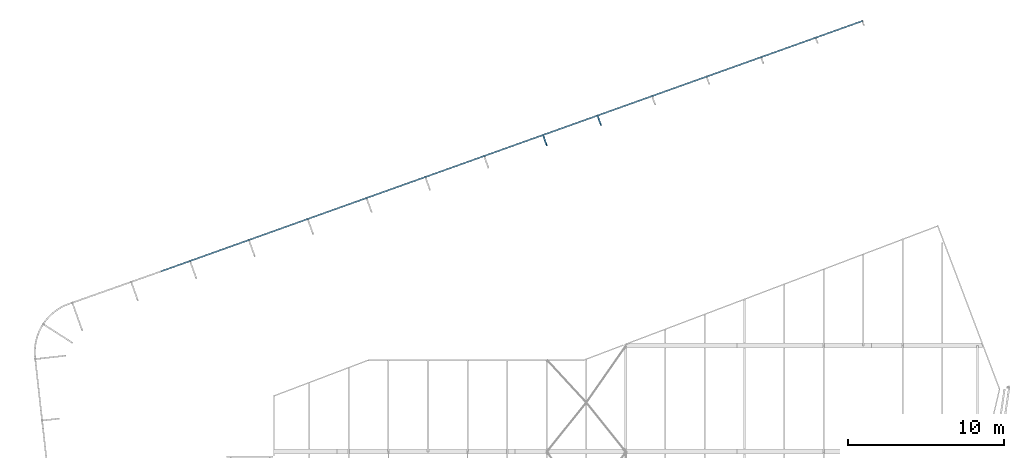
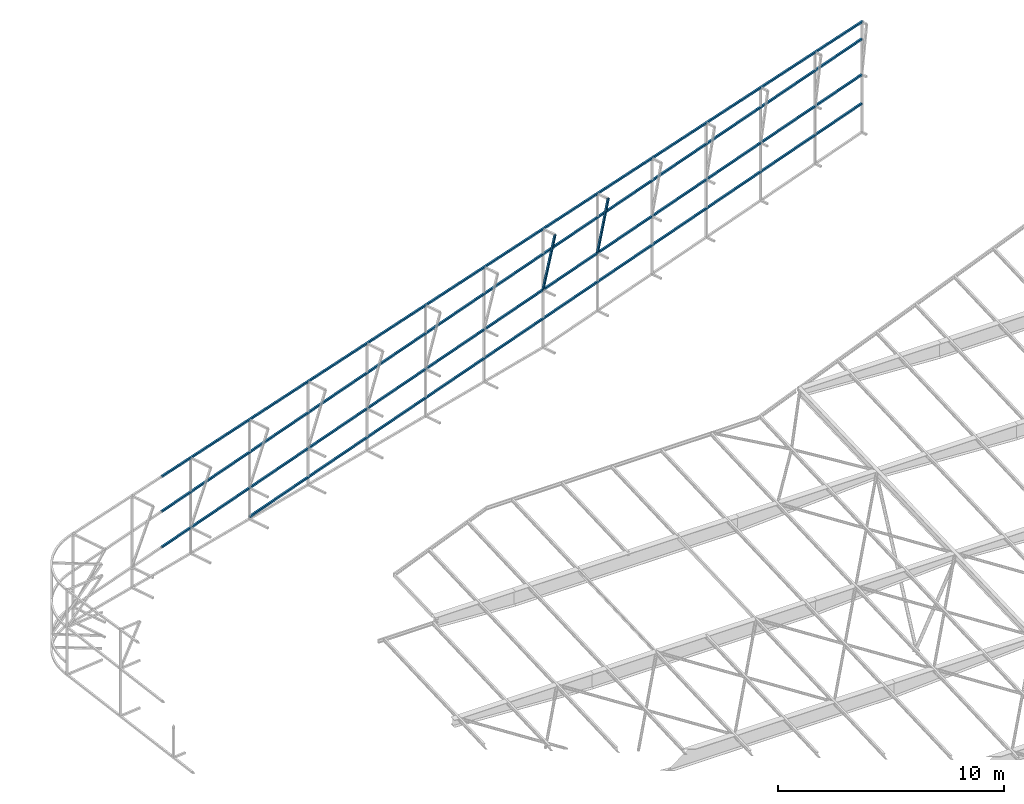
# One storey, part 133 of 215: 4 beams, 2 members, 6 elements without a shape of their own.
"""IFC2X3 building model written with IfcOpenShell, lengths in millimetres."""

from ifc_helpers import new_model, si_unit, frame, origin_with_axes, origin_2d_with_axis, place, context, subcontext, project, spatial, hollow_rectangle, extrude, material, type_object, element, aggregate, save


model = new_model("IFC2X3")

# Units and contexts
model_context = context("Model", 3, precision=1e-05, world=origin_with_axes())
body_context = subcontext(model_context, "Body", "Model", "MODEL_VIEW")
ifc_project = project(units=[si_unit("LENGTHUNIT", "METRE", prefix="MILLI"), si_unit("AREAUNIT", "SQUARE_METRE"), si_unit("VOLUMEUNIT", "CUBIC_METRE"), si_unit("MASSUNIT", "GRAM", prefix="KILO"), si_unit("TIMEUNIT", "SECOND"), si_unit("PLANEANGLEUNIT", "RADIAN"), si_unit("SOLIDANGLEUNIT", "STERADIAN"), si_unit("THERMODYNAMICTEMPERATUREUNIT", "DEGREE_CELSIUS"), si_unit("LUMINOUSINTENSITYUNIT", "LUMEN")], contexts=[model_context])

# Site, building, storey
site_placement = place(None, origin_with_axes())
site = spatial("IfcSite", under=ifc_project, at=site_placement, CompositionType="ELEMENT")
building_placement = place(site_placement, origin_with_axes())
building = spatial("IfcBuilding", under=site, at=building_placement, Name="Undefined", CompositionType="ELEMENT")
storey_placement = place(building_placement, origin_with_axes())
storey = spatial("IfcBuildingStorey", under=building, at=storey_placement, Name="Undefined", CompositionType="ELEMENT", Elevation=0.0)

# Assembly, beam
assembly_1_placement = place(storey_placement, origin_with_axes())
assembly_1 = element("IfcElementAssembly", 1, at=assembly_1_placement, inside=storey, Name="Steel Assembly", AssemblyPlace="NOTDEFINED", PredefinedType="RIGID_FRAME")
ifc_material = material(Name="STEEL/S275JR")
beam_type = type_object("IfcBeamType", PredefinedType="NOTDEFINED")
beam_1_placement = place(assembly_1_placement, frame((105326.104020235, 76175.269389609, 1704.99989208878), z_axis=(0.0, 0.0, -1.0), x_axis=(0.941802170974673, 0.33616762299096, 0.0)))
beam_1 = element("IfcBeam", 2, at=beam_1_placement, type_object=beam_type, material=ifc_material, Name="LISSE", context=body_context, shape_type="SweptSolid", body=[
    extrude(hollow_rectangle(XDim=100.0, YDim=100.0, WallThickness=4.0, InnerFilletRadius=4.0, OuterFilletRadius=8.0, at=origin_2d_with_axis()), frame((41820.4772396688, 7.27595761418343e-12, 0.0), z_axis=(-1.0, 0.0, 0.0), x_axis=(-6.93889390390723e-18, -1.0, -3.46944695195361e-18)), (0.0, 0.0, 1.0), 41820.5),
])
aggregate(assembly_1, [beam_1])

assembly_2_placement = place(storey_placement, origin_with_axes())
assembly_2 = element("IfcElementAssembly", 3, at=assembly_2_placement, inside=storey, Name="Steel Assembly", AssemblyPlace="NOTDEFINED", PredefinedType="RIGID_FRAME")
beam_2_placement = place(assembly_2_placement, frame((99675.6177684888, 74158.3802872295, 5186.05790994558), z_axis=(0.0, 0.0, -1.0), x_axis=(0.941802170974673, 0.33616762299096, 0.0)))
beam_2 = element("IfcBeam", 4, at=beam_2_placement, type_object=beam_type, material=ifc_material, Name="LISSE", context=body_context, shape_type="SweptSolid", body=[
    extrude(hollow_rectangle(XDim=100.0, YDim=100.0, WallThickness=4.0, InnerFilletRadius=4.0, OuterFilletRadius=8.0, at=origin_2d_with_axis()), frame((47820.128325497, -2.65455037537482e-12, 0.0), z_axis=(-1.0, 0.0, 0.0), x_axis=(-6.93889390390723e-18, -1.0, -3.46944695195361e-18)), (0.0, 0.0, 1.0), 47820.1),
])
aggregate(assembly_2, [beam_2])

assembly_3_placement = place(storey_placement, origin_with_axes())
assembly_3 = element("IfcElementAssembly", 5, at=assembly_3_placement, inside=storey, Name="Steel Assembly", AssemblyPlace="NOTDEFINED", PredefinedType="RIGID_FRAME")
beam_3_placement = place(assembly_3_placement, frame((99675.6177684151, 74158.380287177, 3259.99790994558), z_axis=(0.0, 0.0, -1.0), x_axis=(0.941802170974673, 0.33616762299096, 0.0)))
beam_3 = element("IfcBeam", 6, at=beam_3_placement, type_object=beam_type, material=ifc_material, Name="LISSE", context=body_context, shape_type="SweptSolid", body=[
    extrude(hollow_rectangle(XDim=100.0, YDim=100.0, WallThickness=4.0, InnerFilletRadius=4.0, OuterFilletRadius=8.0, at=origin_2d_with_axis()), frame((47820.128325497, -2.65455037537482e-12, 0.0), z_axis=(-1.0, 0.0, 0.0), x_axis=(-6.93889390390723e-18, -1.0, -3.46944695195361e-18)), (0.0, 0.0, 1.0), 47820.1),
])
aggregate(assembly_3, [beam_3])

assembly_4_placement = place(storey_placement, origin_with_axes())
assembly_4 = element("IfcElementAssembly", 7, at=assembly_4_placement, inside=storey, Name="Steel Assembly", AssemblyPlace="NOTDEFINED", PredefinedType="RIGID_FRAME")
beam_4_placement = place(assembly_4_placement, frame((99674.668114869, 74158.0409739412, 7070.43562400573), z_axis=(-0.0189932160034524, -0.0067863100012285, -0.999796581181599), x_axis=(0.941610590477688, 0.336099240813566, -0.0201691899888121)))
beam_4 = element("IfcBeam", 8, at=beam_4_placement, type_object=beam_type, material=ifc_material, Name="LISSE", context=body_context, shape_type="SweptSolid", body=[
    extrude(hollow_rectangle(XDim=100.0, YDim=100.0, WallThickness=4.0, InnerFilletRadius=4.0, OuterFilletRadius=8.0, at=origin_2d_with_axis()), frame((47882.3866464287, 1.51911999189181e-11, -1.66125400402717e-13), z_axis=(-1.0, 0.0, 0.0), x_axis=(-6.93889390390723e-18, -1.0, -3.46944695195361e-18)), (0.0, 0.0, 1.0), 47882.4),
])
aggregate(assembly_4, [beam_4])

# Assembly, member
assembly_5_placement = place(storey_placement, origin_with_axes())
assembly_5 = element("IfcElementAssembly", 9, at=assembly_5_placement, inside=storey, Name="Steel Assembly", AssemblyPlace="NOTDEFINED", PredefinedType="RIGID_FRAME")
member_type = type_object("IfcMemberType", PredefinedType="NOTDEFINED")
member_1_placement = place(assembly_5_placement, frame((127920.570362248, 83569.4991896166, 6504.04384983193), z_axis=(0.941802170974673, 0.33616762299096, 0.0), x_axis=(-0.0642444429927004, 0.17998634797955, -0.981568930888474)))
member_1 = element("IfcMember", 10, at=member_1_placement, type_object=member_type, material=ifc_material, Name="LISSE", context=body_context, shape_type="SweptSolid", body=[
    extrude(hollow_rectangle(XDim=100.0, YDim=100.0, WallThickness=4.0, InnerFilletRadius=4.0, OuterFilletRadius=8.0, at=origin_2d_with_axis()), frame((3304.95988411025, 0.0, -4.88559169176099e-14), z_axis=(-1.0, 0.0, 0.0), x_axis=(-6.93889390390723e-18, -1.0, -3.46944695195361e-18)), (0.0, 0.0, 1.0), 3305.0),
])
aggregate(assembly_5, [member_1])

assembly_6_placement = place(storey_placement, origin_with_axes())
assembly_6 = element("IfcElementAssembly", 11, at=assembly_6_placement, inside=storey, Name="Steel Assembly", AssemblyPlace="NOTDEFINED", PredefinedType="RIGID_FRAME")
member_2_placement = place(assembly_6_placement, frame((124443.198593843, 82254.4263033113, 6544.94519401528), z_axis=(0.941802170974673, 0.33616762299096, 0.0), x_axis=(-0.0701754340055152, 0.196602443015447, -0.977968756076847)))
member_2 = element("IfcMember", 12, at=member_2_placement, type_object=member_type, material=ifc_material, Name="LISSE", context=body_context, shape_type="SweptSolid", body=[
    extrude(hollow_rectangle(XDim=100.0, YDim=100.0, WallThickness=4.0, InnerFilletRadius=4.0, OuterFilletRadius=8.0, at=origin_2d_with_axis()), frame((3358.94911113037, -7.46241674626948e-12, -2.90376684890172e-11), z_axis=(-1.0, 0.0, 0.0), x_axis=(-6.93889390390723e-18, -1.0, -3.46944695195361e-18)), (0.0, 0.0, 1.0), 3358.9),
])
aggregate(assembly_6, [member_2])

save(model, "model.ifc")
